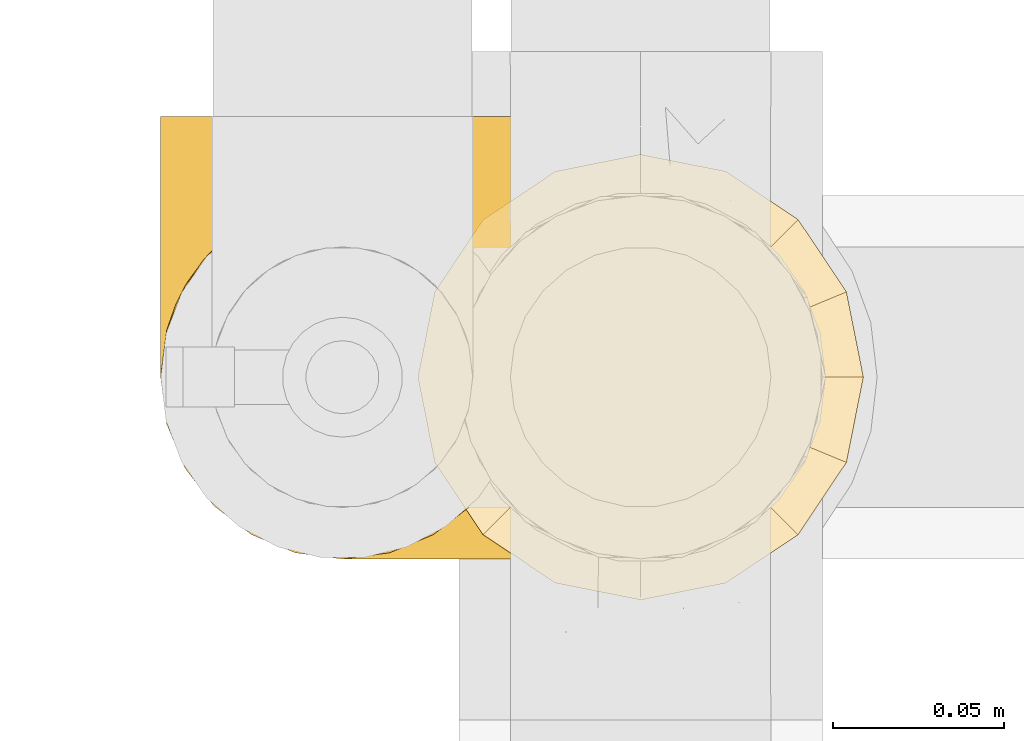
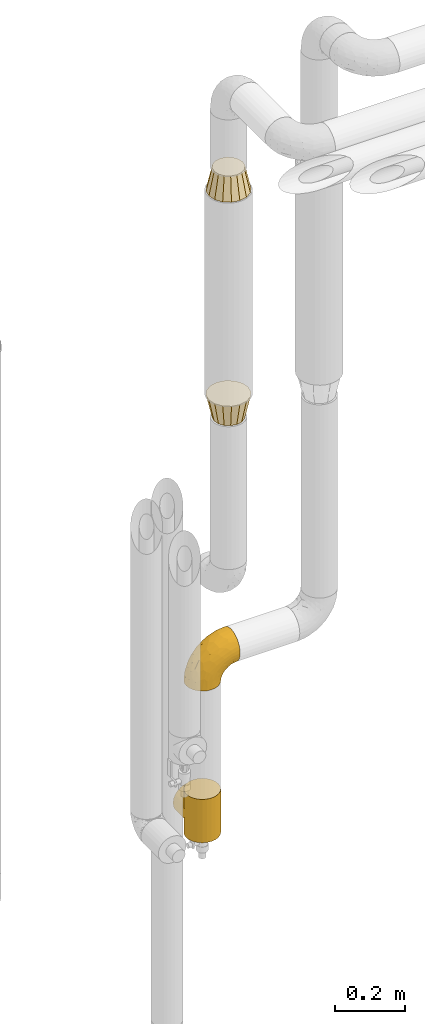
# One storey, part 320 of 827: 4 coverings.
"""IFC2X3 building model written with IfcOpenShell, lengths in millimetres."""

from ifc_helpers import new_model, entity, si_unit, converted_unit, derived_unit, direction, frame, origin, place, context, subcontext, project, spatial, faceted_brep, element, save


model = new_model("IFC2X3")

# Units and contexts
model_context = context("Model", 3, precision=0.01, world=origin(), true_north=direction((6.12303176911189e-17, 1.0)))
body_context = subcontext(model_context, "Body", "Model", "MODEL_VIEW")
ifc_project = project(units=[si_unit("LENGTHUNIT", "METRE", prefix="MILLI"), si_unit("AREAUNIT", "SQUARE_METRE"), si_unit("VOLUMEUNIT", "CUBIC_METRE"), converted_unit("PLANEANGLEUNIT", "DEGREE", entity("IfcRatioMeasure", 0.0174532925199433), si_unit("PLANEANGLEUNIT", "RADIAN"), dimensions=[0, 0, 0, 0, 0, 0, 0]), si_unit("MASSUNIT", "GRAM", prefix="KILO"), derived_unit("MASSDENSITYUNIT", [(si_unit("MASSUNIT", "GRAM", prefix="KILO"), 1), (si_unit("LENGTHUNIT", "METRE"), -3)]), derived_unit("MOMENTOFINERTIAUNIT", [(si_unit("LENGTHUNIT", "METRE"), 4)]), si_unit("TIMEUNIT", "SECOND"), si_unit("FREQUENCYUNIT", "HERTZ"), si_unit("THERMODYNAMICTEMPERATUREUNIT", "DEGREE_CELSIUS"), derived_unit("THERMALTRANSMITTANCEUNIT", [(si_unit("MASSUNIT", "GRAM", prefix="KILO"), 1), (si_unit("THERMODYNAMICTEMPERATUREUNIT", "KELVIN"), -1), (si_unit("TIMEUNIT", "SECOND"), -3)]), derived_unit("VOLUMETRICFLOWRATEUNIT", [(si_unit("LENGTHUNIT", "METRE"), 3), (si_unit("TIMEUNIT", "SECOND"), -1)]), derived_unit("MASSFLOWRATEUNIT", [(si_unit("MASSUNIT", "GRAM", prefix="KILO"), 1), (si_unit("TIMEUNIT", "SECOND"), -1)]), derived_unit("ROTATIONALFREQUENCYUNIT", [(si_unit("TIMEUNIT", "SECOND"), -1)]), si_unit("ELECTRICCURRENTUNIT", "AMPERE"), si_unit("ELECTRICVOLTAGEUNIT", "VOLT"), si_unit("POWERUNIT", "WATT"), si_unit("FORCEUNIT", "NEWTON", prefix="KILO"), si_unit("ILLUMINANCEUNIT", "LUX"), si_unit("LUMINOUSFLUXUNIT", "LUMEN"), si_unit("LUMINOUSINTENSITYUNIT", "CANDELA"), derived_unit("USERDEFINED", [(si_unit("MASSUNIT", "GRAM", prefix="KILO"), -1), (si_unit("LENGTHUNIT", "METRE"), -2), (si_unit("TIMEUNIT", "SECOND"), 3), (si_unit("LUMINOUSFLUXUNIT", "LUMEN"), 1)]), derived_unit("LINEARVELOCITYUNIT", [(si_unit("LENGTHUNIT", "METRE"), 1), (si_unit("TIMEUNIT", "SECOND"), -1)]), si_unit("PRESSUREUNIT", "PASCAL"), derived_unit("USERDEFINED", [(si_unit("LENGTHUNIT", "METRE"), -2), (si_unit("MASSUNIT", "GRAM", prefix="KILO"), 1), (si_unit("TIMEUNIT", "SECOND"), -2)]), derived_unit("LINEARFORCEUNIT", [(si_unit("MASSUNIT", "GRAM", prefix="KILO"), 1), (si_unit("LENGTHUNIT", "METRE"), 1), (si_unit("TIMEUNIT", "SECOND"), -2), (si_unit("LENGTHUNIT", "METRE"), -1)]), derived_unit("PLANARFORCEUNIT", [(si_unit("MASSUNIT", "GRAM", prefix="KILO"), 1), (si_unit("LENGTHUNIT", "METRE"), 1), (si_unit("TIMEUNIT", "SECOND"), -2), (si_unit("LENGTHUNIT", "METRE"), -2)])], contexts=[model_context])

# Site, building, storey
site_placement = place(None, origin())
site = spatial("IfcSite", under=ifc_project, at=site_placement, CompositionType="ELEMENT")
building_placement = place(site_placement, origin())
building = spatial("IfcBuilding", under=site, at=building_placement, CompositionType="ELEMENT")
storey_placement = place(building_placement, frame((0.0, 0.0, 28200.0)))
storey = spatial("IfcBuildingStorey", under=building, at=storey_placement, Name="08", CompositionType="ELEMENT", Elevation=28200.0)

# Coverings
covering_1_placement = place(storey_placement, frame((31388.81, 19286.84, 2520.0)))
element("IfcCovering", 1, at=covering_1_placement, inside=storey, Name=":ADSK_", ObjectType=":ADSK_", PredefinedType="INSULATION", context=body_context, shape_type="Brep", body=[
    faceted_brep([(13.59, 31.18, 0.0), (6.54, 41.72, 0.0), (3.35, 57.76, 0.0), (1.6, 66.6, 0.0), (3.35, 75.43, 0.0), (6.54, 91.47, 0.0), (13.59, 102.01, 0.0), (20.63, 112.56, 0.0), (31.18, 119.6, 0.0), (41.72, 126.65, 0.0), (57.76, 129.84, 0.0), (66.6, 131.6, 0.0), (75.43, 129.84, 0.0), (91.47, 126.65, 0.0), (102.01, 119.6, 0.0), (112.56, 112.56, 0.0), (119.6, 102.01, 0.0), (126.65, 91.47, 0.0), (129.84, 75.43, 0.0), (131.6, 66.6, 0.0), (129.84, 57.76, 0.0), (126.65, 41.72, 0.0), (119.6, 31.18, 0.0), (112.56, 20.63, 0.0), (102.01, 13.59, 0.0), (91.47, 6.54, 0.0), (75.43, 3.35, 0.0), (66.6, 1.6, 0.0), (57.76, 3.35, 0.0), (41.72, 6.54, 0.0), (31.18, 13.59, 0.0), (20.63, 20.63, 0.0), (84.77, 22.71, 80.0), (92.48, 27.86, 80.0), (100.18, 33.01, 80.0), (105.33, 40.71, 80.0), (110.48, 48.42, 80.0), (112.29, 57.51, 80.0), (114.1, 66.6, 80.0), (112.29, 75.68, 80.0), (110.48, 84.77, 80.0), (105.33, 92.48, 80.0), (100.18, 100.18, 80.0), (92.48, 105.33, 80.0), (84.77, 110.48, 80.0), (75.68, 112.29, 80.0), (66.6, 114.1, 80.0), (57.51, 112.29, 80.0), (48.42, 110.48, 80.0), (40.71, 105.33, 80.0), (33.01, 100.18, 80.0), (27.86, 92.48, 80.0), (22.71, 84.77, 80.0), (20.9, 75.68, 80.0), (19.1, 66.6, 80.0), (20.9, 57.51, 80.0), (22.71, 48.42, 80.0), (27.86, 40.71, 80.0), (33.01, 33.01, 80.0), (40.71, 27.86, 80.0), (48.42, 22.71, 80.0), (57.51, 20.9, 80.0), (66.6, 19.1, 80.0), (75.68, 20.9, 80.0)], [[[0, 1, 2, 3, 4, 5, 6, 7, 8, 9, 10, 11, 12, 13, 14, 15, 16, 17, 18, 19, 20, 21, 22, 23, 24, 25, 26, 27, 28, 29, 30, 31]], [[32, 33, 34, 35, 36, 37, 38, 39, 40, 41, 42, 43, 44, 45, 46, 47, 48, 49, 50, 51, 52, 53, 54, 55, 56, 57, 58, 59, 60, 61, 62, 63]], [[6, 5, 52, 51, 50, 7]], [[48, 9, 8, 7, 50, 49]], [[5, 4, 3, 54, 53, 52]], [[10, 9, 48, 47, 46, 11]], [[14, 13, 44, 43, 42, 15]], [[40, 17, 16, 15, 42, 41]], [[13, 12, 11, 46, 45, 44]], [[18, 17, 40, 39, 38, 19]], [[22, 21, 36, 35, 34, 23]], [[32, 25, 24, 23, 34, 33]], [[21, 20, 19, 38, 37, 36]], [[26, 25, 32, 63, 62, 27]], [[30, 29, 60, 59, 58, 31]], [[56, 1, 0, 31, 58, 57]], [[29, 28, 27, 62, 61, 60]], [[2, 1, 56, 55, 54, 3]]]),
])
covering_2_placement = place(storey_placement, frame((31388.81, 19286.84, 1725.45)))
element("IfcCovering", 2, at=covering_2_placement, inside=storey, Name=":ADSK_", ObjectType=":ADSK_", PredefinedType="INSULATION", context=body_context, shape_type="Brep", body=[
    faceted_brep([(84.77, 22.71, 0.0), (75.68, 20.9, 0.0), (66.6, 19.1, 0.0), (57.51, 20.9, 0.0), (48.42, 22.71, 0.0), (40.71, 27.86, 0.0), (33.01, 33.01, 0.0), (27.86, 40.71, 0.0), (22.71, 48.42, 0.0), (20.9, 57.51, 0.0), (19.1, 66.6, 0.0), (20.9, 75.68, 0.0), (22.71, 84.77, 0.0), (27.86, 92.48, 0.0), (33.01, 100.18, 0.0), (40.71, 105.33, 0.0), (48.42, 110.48, 0.0), (57.51, 112.29, 0.0), (66.6, 114.1, 0.0), (75.68, 112.29, 0.0), (84.77, 110.48, 0.0), (92.48, 105.33, 0.0), (100.18, 100.18, 0.0), (105.33, 92.48, 0.0), (110.48, 84.77, 0.0), (112.29, 75.68, 0.0), (114.1, 66.6, 0.0), (112.29, 57.51, 0.0), (110.48, 48.42, 0.0), (105.33, 40.71, 0.0), (100.18, 33.01, 0.0), (92.48, 27.86, 0.0), (112.56, 20.63, 80.0), (119.6, 31.18, 80.0), (126.65, 41.72, 80.0), (129.12, 54.16, 80.0), (131.6, 66.6, 80.0), (129.84, 75.43, 80.0), (126.65, 91.47, 80.0), (119.6, 102.01, 80.0), (112.56, 112.56, 80.0), (102.01, 119.6, 80.0), (91.47, 126.65, 80.0), (79.03, 129.12, 80.0), (66.6, 131.6, 80.0), (57.76, 129.84, 80.0), (41.72, 126.65, 80.0), (31.18, 119.6, 80.0), (20.63, 112.56, 80.0), (13.59, 102.01, 80.0), (6.54, 91.47, 80.0), (4.07, 79.03, 80.0), (1.6, 66.6, 80.0), (3.35, 57.76, 80.0), (6.54, 41.72, 80.0), (13.59, 31.18, 80.0), (20.63, 20.63, 80.0), (31.18, 13.59, 80.0), (41.72, 6.54, 80.0), (54.16, 4.07, 80.0), (66.6, 1.6, 80.0), (75.43, 3.35, 80.0), (91.47, 6.54, 80.0), (102.01, 13.59, 80.0)], [[[0, 1, 2, 3, 4, 5, 6, 7, 8, 9, 10, 11, 12, 13, 14, 15, 16, 17, 18, 19, 20, 21, 22, 23, 24, 25, 26, 27, 28, 29, 30, 31]], [[32, 33, 34, 35, 36, 37, 38, 39, 40, 41, 42, 43, 44, 45, 46, 47, 48, 49, 50, 51, 52, 53, 54, 55, 56, 57, 58, 59, 60, 61, 62, 63]], [[46, 45, 44, 18, 17, 16]], [[47, 46, 16, 15, 14, 48]], [[14, 13, 12, 50, 49, 48]], [[10, 52, 51, 50, 12, 11]], [[38, 37, 36, 26, 25, 24]], [[39, 38, 24, 23, 22, 40]], [[22, 21, 20, 42, 41, 40]], [[18, 44, 43, 42, 20, 19]], [[62, 61, 60, 2, 1, 0]], [[63, 62, 0, 31, 30, 32]], [[30, 29, 28, 34, 33, 32]], [[26, 36, 35, 34, 28, 27]], [[54, 53, 52, 10, 9, 8]], [[55, 54, 8, 7, 6, 56]], [[6, 5, 4, 58, 57, 56]], [[2, 60, 59, 58, 4, 3]]]),
])
covering_3_placement = place(storey_placement, frame((31313.76, 19298.79, 299.0)))
element("IfcCovering", 3, at=covering_3_placement, inside=storey, Name=":ADSK_", ObjectType=":ADSK_", PredefinedType="INSULATION", context=body_context, shape_type="Brep", body=[
    faceted_brep([(2.08, 61.79, 83.14), (1.6, 54.65, 152.0), (3.4, 68.38, 152.0), (8.7, 81.17, 152.0), (6.0, 75.81, 97.16), (14.13, 88.89, 110.24), (17.13, 92.16, 152.0), (9.51, 82.52, 103.87), (1.6, 54.65, 76.0), (2.08, 61.79, 68.86), (1.6, 54.65, 0.0), (3.54, 68.87, 90.22), (19.93, 94.76, 116.11), (28.12, 100.59, 152.0), (35.26, 104.03, 125.38), (34.52, 103.24, 152.0), (40.91, 105.89, 152.0), (47.78, 106.79, 152.0), (54.65, 107.7, 152.0), (54.65, 107.7, 129.05), (47.78, 106.79, 0.0), (54.65, 107.7, 22.95), (54.65, 107.7, 0.0), (26.97, 99.91, 121.26), (44.63, 106.74, 128.1), (65.76, 106.52, 127.87), (65.76, 106.52, 24.13), (68.38, 105.89, 152.0), (75.98, 103.22, 124.57), (74.77, 103.24, 152.0), (81.17, 100.59, 152.0), (92.16, 92.16, 152.0), (92.09, 92.23, 113.58), (84.81, 98.29, 119.64), (97.87, 85.4, 106.76), (100.59, 81.17, 152.0), (102.24, 78.08, 99.43), (105.89, 68.38, 152.0), (107.1, 62.58, 83.94), (107.7, 54.65, 152.0), (105.29, 70.43, 91.78), (107.7, 54.65, 76.0), (107.1, 62.58, 68.06), (107.7, 54.65, 0.0), (68.38, 3.4, 0.0), (54.65, 1.6, 0.0), (40.91, 3.4, 0.0), (28.12, 8.7, 0.0), (17.13, 17.13, 0.0), (8.7, 28.12, 0.0), (3.4, 40.91, 0.0), (3.4, 68.38, 0.0), (8.7, 81.17, 0.0), (17.13, 92.16, 0.0), (28.12, 100.59, 0.0), (34.52, 103.24, 0.0), (40.91, 105.89, 0.0), (68.38, 105.89, 0.0), (74.77, 103.24, 0.0), (81.17, 100.59, 0.0), (92.16, 92.16, 0.0), (100.59, 81.17, 0.0), (105.89, 68.38, 0.0), (105.89, 40.91, 0.0), (100.59, 28.12, 0.0), (92.16, 17.13, 0.0), (81.17, 8.7, 0.0), (3.4, 40.91, 152.0), (8.7, 28.12, 152.0), (17.13, 17.13, 152.0), (28.12, 8.7, 152.0), (40.91, 3.4, 152.0), (54.65, 1.6, 152.0), (68.38, 3.4, 152.0), (81.17, 8.7, 152.0), (92.16, 17.13, 152.0), (100.59, 28.12, 152.0), (105.89, 40.91, 152.0), (3.54, 68.87, 61.78), (6.0, 75.81, 54.84), (9.51, 82.52, 48.13), (14.13, 88.89, 41.76), (19.93, 94.76, 35.89), (26.97, 99.91, 30.74), (35.26, 104.03, 26.62), (44.63, 106.74, 23.9), (75.98, 103.22, 27.43), (84.81, 98.29, 32.36), (92.09, 92.23, 38.42), (102.24, 78.08, 52.57), (105.29, 70.43, 60.22), (97.87, 85.4, 45.24), (1.6, 130.65, 76.0), (3.4, 130.65, 89.73), (8.7, 130.65, 102.53), (17.13, 130.65, 113.51), (28.12, 130.65, 121.94), (34.52, 130.65, 124.59), (40.91, 130.65, 127.24), (47.78, 130.65, 128.15), (54.65, 130.65, 129.05), (68.38, 130.65, 127.24), (74.77, 130.65, 124.59), (81.17, 130.65, 121.94), (92.16, 130.65, 113.51), (100.59, 130.65, 102.53), (105.89, 130.65, 89.73), (107.7, 130.65, 76.0), (105.89, 130.65, 62.27), (100.59, 130.65, 49.47), (92.16, 130.65, 38.49), (81.17, 130.65, 30.06), (74.77, 130.65, 27.41), (68.38, 130.65, 24.76), (54.65, 130.65, 22.95), (47.78, 130.65, 23.85), (40.91, 130.65, 24.76), (34.52, 130.65, 27.41), (28.12, 130.65, 30.06), (17.13, 130.65, 38.49), (8.7, 130.65, 49.47), (3.4, 130.65, 62.27)], [[[0, 1, 2]], [[2, 3, 4]], [[5, 3, 6]], [[5, 7, 3]], [[0, 8, 1]], [[8, 9, 10]], [[4, 11, 2]], [[7, 4, 3]], [[0, 2, 11]], [[12, 6, 13]], [[14, 13, 15, 16]], [[17, 18, 19]], [[20, 21, 22]], [[23, 12, 13]], [[24, 14, 16]], [[24, 17, 19]], [[24, 16, 17]], [[23, 13, 14]], [[6, 12, 5]], [[25, 19, 18]], [[21, 26, 22]], [[25, 18, 27]], [[28, 27, 29, 30]], [[28, 25, 27]], [[31, 32, 33]], [[28, 30, 33]], [[33, 30, 31]], [[34, 31, 35]], [[36, 35, 37]], [[38, 37, 39]], [[36, 34, 35]], [[38, 40, 37]], [[41, 38, 39]], [[42, 41, 43]], [[36, 37, 40]], [[31, 34, 32]], [[44, 45, 46, 47, 48, 49, 50, 10, 51, 52, 53, 54, 55, 56, 20, 22, 57, 58, 59, 60, 61, 62, 43, 63, 64, 65, 66]], [[1, 67, 68, 69, 70, 71, 72, 73, 74, 75, 76, 77, 39, 37, 35, 31, 30, 29, 27, 18, 17, 16, 15, 13, 6, 3, 2]], [[70, 69, 48, 47]], [[45, 72, 71, 46]], [[46, 71, 70, 47]], [[49, 68, 67, 50]], [[1, 8, 10, 50, 67]], [[48, 69, 68, 49]], [[78, 79, 51]], [[9, 78, 51]], [[10, 9, 51]], [[52, 80, 81]], [[52, 51, 79]], [[52, 81, 53]], [[80, 52, 79]], [[82, 83, 54]], [[84, 56, 55, 54]], [[84, 85, 56]], [[21, 20, 85]], [[83, 84, 54]], [[53, 82, 54]], [[85, 20, 56]], [[82, 53, 81]], [[26, 86, 57]], [[59, 87, 60]], [[86, 59, 58, 57]], [[86, 87, 59]], [[22, 26, 57]], [[87, 88, 60]], [[89, 90, 62]], [[90, 42, 62]], [[60, 91, 61]], [[91, 60, 88]], [[89, 61, 91]], [[89, 62, 61]], [[42, 43, 62]], [[41, 39, 77, 63, 43]], [[63, 77, 76, 64]], [[76, 75, 65, 64]], [[65, 75, 74, 66]], [[66, 74, 73, 44]], [[44, 73, 72, 45]], [[92, 93, 94, 95, 96, 97, 98, 99, 100, 101, 102, 103, 104, 105, 106, 107, 108, 109, 110, 111, 112, 113, 114, 115, 116, 117, 118, 119, 120, 121]], [[24, 99, 98]], [[96, 95, 12]], [[14, 98, 97, 96]], [[19, 99, 24]], [[19, 100, 99]], [[23, 14, 96]], [[12, 23, 96]], [[24, 98, 14]], [[95, 5, 12]], [[7, 5, 94]], [[94, 5, 95]], [[4, 94, 93]], [[0, 93, 92]], [[4, 7, 94]], [[0, 11, 93]], [[8, 0, 92]], [[4, 93, 11]], [[9, 92, 121]], [[121, 120, 79]], [[81, 120, 119]], [[81, 80, 120]], [[9, 8, 92]], [[79, 78, 121]], [[80, 79, 120]], [[9, 121, 78]], [[82, 119, 118]], [[84, 118, 117, 116]], [[115, 114, 21]], [[83, 82, 118]], [[85, 84, 116]], [[85, 115, 21]], [[85, 116, 115]], [[83, 118, 84]], [[119, 82, 81]], [[26, 21, 114]], [[26, 114, 113]], [[86, 113, 112, 111]], [[86, 26, 113]], [[110, 88, 87]], [[86, 111, 87]], [[87, 111, 110]], [[91, 110, 109]], [[89, 109, 108]], [[42, 108, 107]], [[89, 91, 109]], [[42, 90, 108]], [[41, 42, 107]], [[89, 108, 90]], [[110, 91, 88]], [[38, 107, 106]], [[106, 105, 36]], [[34, 105, 104]], [[34, 36, 105]], [[38, 41, 107]], [[36, 40, 106]], [[38, 106, 40]], [[33, 104, 103]], [[28, 103, 102, 101]], [[25, 101, 100]], [[33, 32, 104]], [[25, 28, 101]], [[19, 25, 100]], [[33, 103, 28]], [[104, 32, 34]]]),
])
covering_4_placement = place(storey_placement, frame((31313.76, 19298.79, 828.67)))
element("IfcCovering", 4, at=covering_4_placement, inside=storey, Name=":ADSK_", ObjectType=":ADSK_", PredefinedType="INSULATION", context=body_context, shape_type="Brep", body=[
    faceted_brep([(149.65, 66.44, 148.32), (149.65, 54.65, 149.65), (149.65, 42.84, 148.31), (149.65, 31.62, 144.39), (149.65, 21.56, 138.06), (149.65, 13.16, 129.66), (149.65, 6.84, 119.6), (149.65, 2.92, 108.39), (149.65, 1.6, 96.6), (149.65, 2.93, 84.79), (149.65, 6.85, 73.57), (149.65, 13.18, 63.51), (149.65, 21.58, 55.11), (149.65, 31.64, 48.79), (149.65, 42.85, 44.87), (149.65, 54.65, 43.55), (149.65, 66.46, 44.88), (149.65, 77.67, 48.8), (149.65, 87.73, 55.13), (149.65, 96.13, 63.53), (149.65, 102.45, 73.59), (149.65, 106.37, 84.8), (149.65, 107.7, 96.6), (149.65, 106.36, 108.41), (149.65, 102.44, 119.62), (149.65, 96.11, 129.68), (149.65, 87.71, 138.08), (149.65, 77.65, 144.4), (105.89, 40.91, 1.6), (100.59, 28.12, 1.6), (92.16, 17.13, 1.6), (81.17, 8.7, 1.6), (68.38, 3.4, 1.6), (54.65, 1.6, 1.6), (40.91, 3.4, 1.6), (28.12, 8.7, 1.6), (17.13, 17.13, 1.6), (8.7, 28.12, 1.6), (3.4, 40.91, 1.6), (1.6, 54.65, 1.6), (3.4, 68.38, 1.6), (8.7, 81.17, 1.6), (17.13, 92.16, 1.6), (28.12, 100.59, 1.6), (40.91, 105.89, 1.6), (54.65, 107.7, 1.6), (68.38, 105.89, 1.6), (81.17, 100.59, 1.6), (92.16, 92.16, 1.6), (100.59, 81.17, 1.6), (105.89, 68.38, 1.6), (107.7, 54.65, 1.6), (14.05, 85.53, 27.97), (9.45, 73.42, 37.09), (22.36, 83.77, 58.27), (4.7, 64.22, 27.13), (6.64, 54.65, 39.91), (81.47, 96.72, 109.11), (56.83, 93.36, 94.41), (64.02, 84.47, 110.94), (34.04, 71.37, 89.69), (21.43, 54.65, 75.62), (44.96, 54.65, 106.28), (49.8, 103.47, 60.12), (35.43, 100.91, 41.41), (42.1, 99.1, 63.22), (43.59, 105.43, 32.05), (57.88, 106.79, 52.13), (91.8, 89.81, 123.27), (88.01, 79.59, 129.32), (115.65, 81.29, 138.3), (18.94, 74.01, 62.95), (12.83, 64.14, 55.89), (24.96, 94.75, 37.4), (111.33, 54.65, 144.6), (113.8, 70.74, 142.66), (60.89, 68.3, 117.85), (86.24, 66.05, 134.01), (65.84, 100.73, 89.25), (124.58, 106.78, 103.34), (121.36, 103.6, 113.52), (72.79, 107.7, 57.43), (66.04, 107.7, 44.19), (59.29, 107.7, 30.95), (73.26, 106.07, 77.98), (121.69, 90.59, 132.66), (109.82, 97.43, 121.52), (40.11, 84.51, 86.93), (36.57, 93.3, 68.4), (93.81, 107.7, 78.45), (83.3, 107.7, 67.94), (136.6, 107.7, 94.53), (120.29, 107.7, 91.95), (99.11, 106.79, 93.36), (107.05, 107.7, 85.2), (91.12, 103.47, 101.45), (75.62, 54.65, 129.81), (56.97, 107.7, 16.27), (126.65, 76.99, 42.46), (116.55, 84.28, 40.4), (120.09, 91.11, 49.71), (76.06, 106.26, 39.4), (83.69, 102.6, 31.26), (71.88, 106.08, 27.7), (66.92, 106.56, 16.7), (110.43, 105.36, 70.67), (121.31, 106.74, 81.69), (81.0, 101.59, 16.68), (113.32, 54.65, 22.57), (111.09, 54.65, 14.26), (109.14, 67.71, 17.68), (95.86, 91.36, 19.58), (99.07, 94.33, 33.49), (106.92, 87.1, 33.01), (131.39, 65.84, 40.69), (136.98, 54.65, 40.15), (128.67, 54.65, 37.93), (117.07, 68.92, 31.04), (96.39, 100.82, 45.29), (106.61, 79.83, 23.55), (103.72, 77.13, 11.36), (92.14, 105.9, 59.1), (107.13, 101.53, 57.42), (98.03, 106.72, 68.96), (88.38, 97.75, 20.38), (130.66, 103.08, 72.46), (135.45, 106.39, 83.66), (123.57, 98.1, 60.66), (137.75, 95.02, 61.01), (133.2, 86.9, 51.85), (138.8, 74.42, 46.07), (120.99, 54.65, 30.25), (84.53, 105.28, 46.65), (108.72, 92.87, 43.0), (95.86, 17.93, 19.58), (130.67, 6.22, 72.44), (109.13, 41.58, 17.67), (93.81, 1.6, 78.45), (98.02, 2.57, 68.97), (110.43, 3.94, 70.65), (131.4, 43.46, 40.69), (126.66, 32.32, 42.45), (117.08, 40.38, 31.04), (108.74, 16.44, 42.99), (96.31, 8.47, 45.18), (99.11, 15.01, 33.46), (123.58, 11.21, 60.64), (107.12, 7.78, 57.37), (72.79, 1.6, 57.43), (66.04, 1.6, 44.19), (76.07, 3.04, 39.35), (56.97, 1.6, 16.27), (66.92, 2.73, 16.7), (120.29, 1.6, 91.95), (107.05, 1.6, 85.2), (121.26, 2.55, 81.68), (84.46, 3.98, 46.68), (83.69, 6.69, 31.26), (81.0, 7.7, 16.68), (71.88, 3.21, 27.7), (137.76, 14.28, 60.99), (133.21, 22.42, 51.84), (116.58, 25.02, 40.41), (120.1, 18.18, 49.72), (138.81, 34.89, 46.06), (136.6, 1.6, 94.53), (103.72, 32.17, 11.35), (106.96, 22.23, 33.02), (135.44, 2.91, 83.65), (88.38, 11.54, 20.38), (83.3, 1.6, 67.94), (106.6, 29.46, 23.53), (92.12, 3.38, 59.12), (59.29, 1.6, 30.95), (22.36, 25.52, 58.27), (14.05, 23.76, 27.97), (24.96, 14.54, 37.4), (35.43, 8.38, 41.41), (4.71, 45.07, 27.21), (9.45, 35.87, 37.09), (11.79, 45.14, 53.2), (57.88, 2.5, 52.13), (124.57, 2.51, 103.34), (121.37, 5.68, 113.5), (91.12, 5.82, 101.45), (56.83, 15.93, 94.41), (81.48, 12.54, 109.08), (64.05, 24.81, 110.95), (99.11, 2.5, 93.36), (73.26, 3.22, 77.98), (43.59, 3.86, 32.05), (19.5, 35.85, 64.63), (91.8, 19.47, 123.25), (121.7, 18.68, 132.65), (88.04, 29.68, 129.32), (123.34, 27.95, 139.96), (60.89, 40.99, 117.85), (34.04, 37.92, 89.69), (109.85, 11.85, 121.51), (42.1, 10.19, 63.23), (65.78, 8.55, 89.17), (113.81, 38.53, 142.66), (36.57, 15.99, 68.4), (40.12, 24.79, 86.94), (49.8, 5.82, 60.12), (86.08, 40.56, 133.2)], [[[0, 1, 2, 3, 4, 5, 6, 7, 8, 9, 10, 11, 12, 13, 14, 15, 16, 17, 18, 19, 20, 21, 22, 23, 24, 25, 26, 27]], [[28, 29, 30, 31, 32, 33, 34, 35, 36, 37, 38, 39, 40, 41, 42, 43, 44, 45, 46, 47, 48, 49, 50, 51]], [[52, 53, 54]], [[55, 39, 56]], [[57, 58, 59]], [[60, 61, 62]], [[63, 64, 65]], [[66, 63, 67]], [[68, 69, 70]], [[53, 71, 54]], [[41, 40, 53]], [[53, 72, 71]], [[73, 42, 52]], [[42, 41, 52]], [[74, 0, 75]], [[69, 76, 77]], [[43, 73, 64]], [[45, 44, 66]], [[57, 78, 58]], [[23, 79, 80]], [[67, 81, 82, 83]], [[67, 84, 81]], [[24, 23, 80]], [[25, 85, 26]], [[86, 85, 25]], [[42, 73, 43]], [[0, 27, 75]], [[25, 24, 86]], [[70, 26, 85]], [[0, 74, 1]], [[68, 85, 86]], [[66, 64, 63]], [[60, 59, 87]], [[54, 87, 88]], [[76, 60, 62]], [[84, 89, 90, 81]], [[79, 22, 91, 92]], [[77, 74, 75]], [[93, 92, 94, 89]], [[80, 86, 24]], [[40, 55, 53]], [[76, 59, 60]], [[93, 84, 95]], [[76, 62, 96]], [[55, 72, 53]], [[70, 27, 26]], [[75, 70, 69]], [[78, 84, 63]], [[93, 79, 92]], [[95, 86, 80]], [[77, 76, 96]], [[59, 69, 68]], [[57, 68, 86]], [[68, 57, 59]], [[59, 58, 87]], [[76, 69, 59]], [[88, 87, 58]], [[87, 54, 71]], [[86, 95, 57]], [[78, 57, 95]], [[84, 78, 95]], [[78, 63, 65]], [[58, 78, 65]], [[54, 88, 73]], [[84, 93, 89]], [[79, 95, 80]], [[79, 93, 95]], [[22, 79, 23]], [[66, 83, 97, 45]], [[84, 67, 63]], [[83, 66, 67]], [[64, 44, 43]], [[64, 66, 44]], [[65, 73, 88]], [[53, 52, 41]], [[73, 52, 54]], [[73, 65, 64]], [[65, 88, 58]], [[39, 55, 40]], [[72, 55, 56]], [[56, 61, 72]], [[60, 72, 61]], [[72, 60, 71]], [[87, 71, 60]], [[27, 70, 75]], [[68, 70, 85]], [[74, 77, 96]], [[69, 77, 75]], [[98, 99, 100]], [[46, 45, 97]], [[101, 102, 103]], [[103, 104, 83]], [[105, 94, 106]], [[107, 103, 102]], [[108, 109, 51, 110]], [[111, 112, 113]], [[114, 115, 116]], [[47, 104, 107]], [[110, 117, 108]], [[49, 48, 111]], [[102, 118, 112]], [[119, 120, 111]], [[50, 49, 120]], [[121, 122, 118]], [[105, 123, 89]], [[124, 48, 107]], [[20, 19, 125]], [[121, 81, 90]], [[117, 119, 99]], [[21, 20, 126]], [[22, 21, 91]], [[105, 125, 127]], [[110, 51, 50]], [[19, 128, 125]], [[16, 15, 115]], [[129, 98, 100]], [[126, 91, 21]], [[128, 129, 127]], [[122, 123, 105]], [[114, 117, 98]], [[17, 16, 130]], [[18, 128, 19]], [[129, 18, 17]], [[125, 106, 126]], [[115, 114, 16]], [[130, 129, 17]], [[114, 98, 130]], [[117, 116, 131, 108]], [[99, 119, 113]], [[122, 121, 123]], [[92, 126, 106]], [[105, 127, 122]], [[132, 121, 118]], [[114, 130, 16]], [[129, 130, 98]], [[50, 120, 110]], [[129, 128, 18]], [[125, 128, 127]], [[125, 126, 20]], [[91, 126, 92]], [[105, 89, 94]], [[105, 106, 125]], [[94, 92, 106]], [[100, 122, 127]], [[118, 122, 133]], [[112, 118, 133]], [[132, 118, 102]], [[132, 102, 101]], [[81, 121, 132]], [[82, 103, 83]], [[132, 101, 81]], [[104, 47, 46]], [[124, 107, 102]], [[48, 47, 107]], [[113, 112, 133]], [[112, 111, 124]], [[99, 113, 133]], [[111, 113, 119]], [[99, 133, 100]], [[117, 99, 98]], [[122, 100, 133]], [[127, 129, 100]], [[103, 82, 101]], [[81, 101, 82]], [[112, 124, 102]], [[48, 124, 111]], [[104, 103, 107]], [[46, 97, 104]], [[111, 120, 49]], [[83, 104, 97]], [[110, 120, 119]], [[117, 110, 119]], [[116, 117, 114]], [[89, 123, 90]], [[90, 123, 121]], [[30, 29, 134]], [[11, 10, 135]], [[51, 109, 108, 136]], [[137, 138, 139]], [[140, 141, 142]], [[143, 144, 145]], [[146, 139, 147]], [[148, 149, 150]], [[151, 32, 152]], [[153, 154, 155]], [[156, 150, 157]], [[158, 157, 159]], [[108, 142, 136]], [[31, 158, 152]], [[160, 161, 12]], [[162, 163, 143]], [[140, 142, 116]], [[142, 141, 162]], [[14, 164, 140]], [[14, 140, 115]], [[9, 8, 165]], [[160, 12, 11]], [[141, 164, 161]], [[13, 12, 161]], [[14, 115, 15]], [[28, 166, 29]], [[135, 139, 146]], [[141, 163, 162]], [[135, 146, 160]], [[143, 167, 162]], [[29, 166, 134]], [[116, 142, 108, 131]], [[165, 153, 168]], [[10, 9, 168]], [[168, 135, 10]], [[138, 147, 139]], [[158, 169, 157]], [[14, 13, 164]], [[116, 115, 140]], [[145, 167, 143]], [[135, 160, 11]], [[168, 153, 155]], [[138, 137, 170]], [[157, 144, 156]], [[147, 144, 143]], [[161, 164, 13]], [[140, 164, 141]], [[142, 171, 136]], [[136, 171, 166]], [[161, 160, 146]], [[165, 168, 9]], [[155, 139, 135]], [[139, 154, 137]], [[168, 155, 135]], [[139, 155, 154]], [[144, 147, 172]], [[163, 147, 143]], [[156, 144, 172]], [[157, 169, 145]], [[172, 148, 156]], [[173, 159, 149]], [[159, 157, 150]], [[152, 159, 173]], [[159, 152, 158]], [[31, 30, 158]], [[169, 30, 134]], [[157, 145, 144]], [[167, 134, 171]], [[134, 167, 145]], [[171, 142, 162]], [[162, 167, 171]], [[163, 141, 161]], [[161, 146, 163]], [[147, 163, 146]], [[148, 150, 156]], [[149, 159, 150]], [[30, 169, 158]], [[145, 169, 134]], [[151, 33, 32]], [[31, 152, 32]], [[152, 173, 151]], [[28, 51, 136]], [[134, 166, 171]], [[28, 136, 166]], [[138, 170, 172]], [[147, 138, 172]], [[148, 172, 170]], [[174, 175, 176]], [[35, 34, 177]], [[178, 179, 180]], [[181, 173, 149, 148]], [[182, 183, 184]], [[185, 186, 187]], [[188, 189, 137]], [[190, 33, 151, 173]], [[191, 179, 174]], [[34, 190, 177]], [[39, 38, 178]], [[192, 193, 194]], [[4, 3, 195]], [[175, 179, 37]], [[38, 37, 179]], [[35, 176, 36]], [[196, 62, 197]], [[181, 190, 173]], [[37, 36, 175]], [[183, 6, 198]], [[189, 148, 170, 137]], [[185, 199, 200]], [[3, 2, 201]], [[202, 185, 203]], [[8, 7, 182]], [[200, 184, 186]], [[183, 7, 6]], [[181, 189, 204]], [[200, 189, 184]], [[5, 198, 6]], [[187, 203, 185]], [[195, 3, 201]], [[205, 196, 194]], [[62, 61, 197]], [[186, 198, 192]], [[180, 179, 191]], [[2, 1, 74]], [[198, 193, 192]], [[193, 5, 4]], [[194, 193, 195]], [[2, 74, 201]], [[5, 193, 198]], [[205, 74, 96]], [[188, 137, 154, 153]], [[62, 196, 96]], [[56, 178, 180]], [[198, 184, 183]], [[184, 188, 182]], [[203, 197, 191]], [[205, 194, 201]], [[187, 192, 194]], [[192, 187, 186]], [[194, 196, 187]], [[197, 187, 196]], [[197, 203, 187]], [[202, 174, 176]], [[200, 186, 185]], [[184, 198, 186]], [[199, 185, 202]], [[189, 200, 204]], [[174, 202, 203]], [[176, 177, 199]], [[189, 181, 148]], [[190, 181, 204]], [[190, 204, 177]], [[190, 34, 33]], [[188, 153, 182]], [[189, 188, 184]], [[182, 153, 165, 8]], [[183, 182, 7]], [[199, 177, 204]], [[35, 177, 176]], [[176, 175, 36]], [[179, 175, 174]], [[200, 199, 204]], [[176, 199, 202]], [[203, 191, 174]], [[180, 197, 61]], [[197, 180, 191]], [[61, 56, 180]], [[39, 178, 56]], [[38, 179, 178]], [[194, 195, 201]], [[4, 195, 193]], [[74, 205, 201]], [[96, 196, 205]]]),
])

save(model, "model.ifc")
